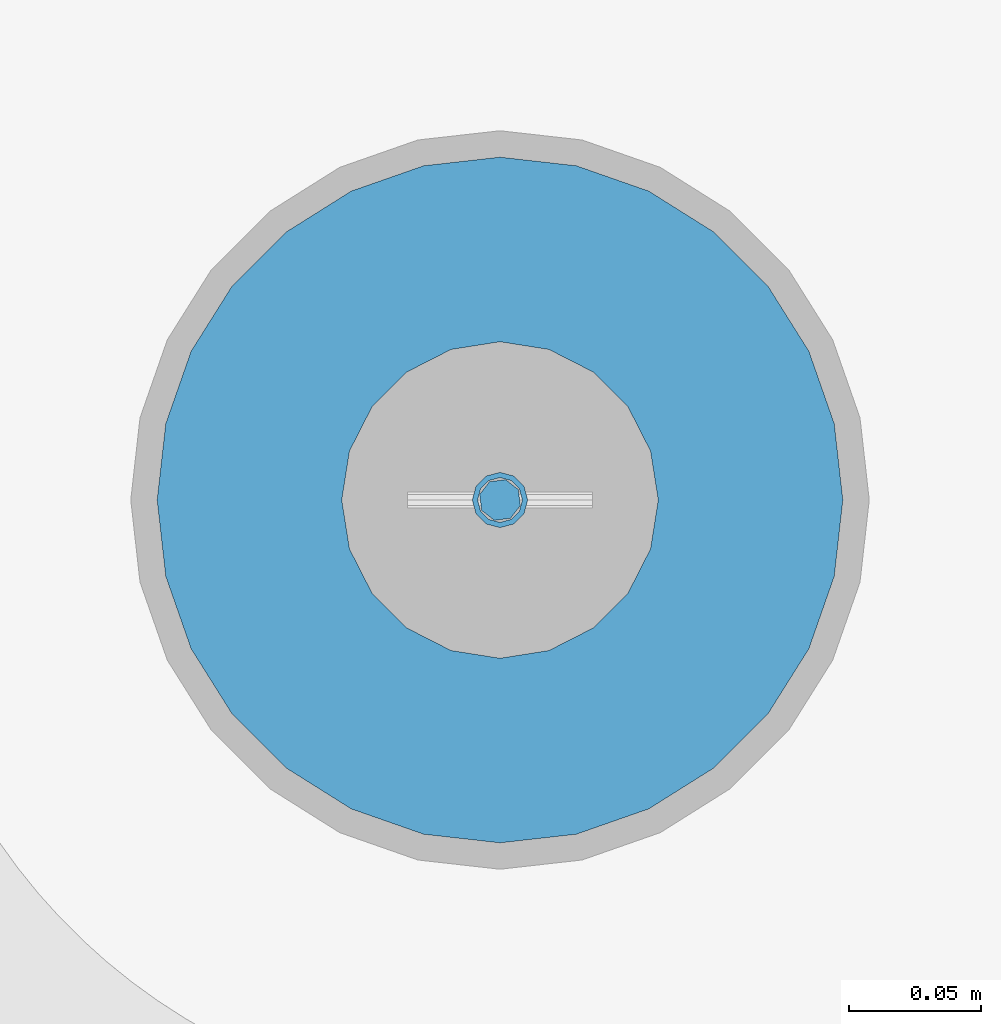
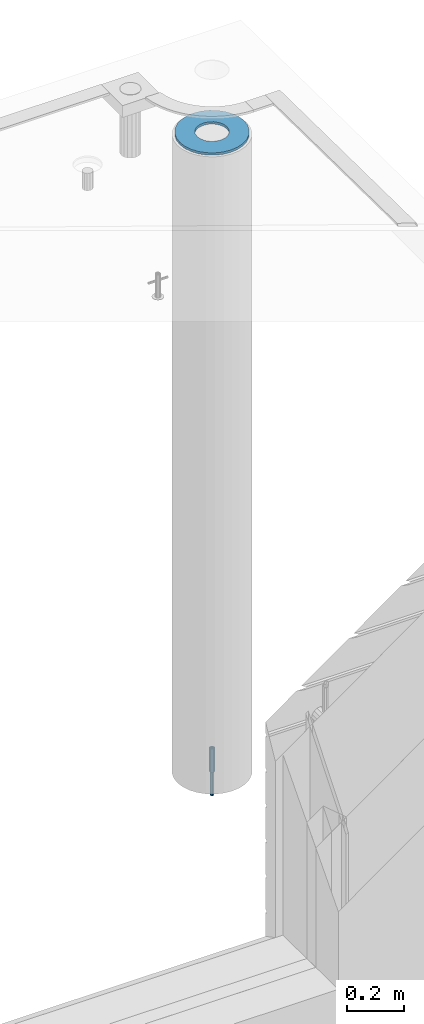
# One storey, part 36 of 334: 3 columns, 3 elements without a shape of their own.
"""IFC2X3 building model written with IfcOpenShell, lengths in millimetres."""

from ifc_helpers import new_model, si_unit, frame, origin_with_axes, place, context, subcontext, project, spatial, faceted_brep, material, type_object, element, aggregate, save


model = new_model("IFC2X3")

# Units and contexts
model_context = context("Model", 3, precision=1e-05, world=origin_with_axes())
body_context = subcontext(model_context, "Body", "Model", "MODEL_VIEW")
ifc_project = project(units=[si_unit("LENGTHUNIT", "METRE", prefix="MILLI"), si_unit("AREAUNIT", "SQUARE_METRE"), si_unit("VOLUMEUNIT", "CUBIC_METRE"), si_unit("MASSUNIT", "GRAM", prefix="KILO"), si_unit("TIMEUNIT", "SECOND"), si_unit("PLANEANGLEUNIT", "RADIAN"), si_unit("SOLIDANGLEUNIT", "STERADIAN"), si_unit("THERMODYNAMICTEMPERATUREUNIT", "DEGREE_CELSIUS"), si_unit("LUMINOUSINTENSITYUNIT", "LUMEN")], contexts=[model_context])

# Site, building, storey
site_placement = place(None, origin_with_axes())
site = spatial("IfcSite", under=ifc_project, at=site_placement, CompositionType="ELEMENT")
building_placement = place(site_placement, origin_with_axes())
building = spatial("IfcBuilding", under=site, at=building_placement, CompositionType="ELEMENT")
storey_placement = place(building_placement, origin_with_axes())
storey = spatial("IfcBuildingStorey", under=building, at=storey_placement, Name="3", CompositionType="ELEMENT", Elevation=0.0)

# Assemblies, columns
assembly_1_placement = place(storey_placement, origin_with_axes())
assembly_1 = element("IfcElementAssembly", 1, at=assembly_1_placement, inside=storey, AssemblyPlace="NOTDEFINED", PredefinedType="REINFORCEMENT_UNIT")
assembly_2_placement = place(assembly_1_placement, origin_with_axes())
assembly_2 = element("IfcElementAssembly", 2, at=assembly_2_placement, Name="Steel Assembly", AssemblyPlace="NOTDEFINED", PredefinedType="RIGID_FRAME")
ifc_material_1 = material(Name="STEEL/S235JR")
column_type_1 = type_object("IfcColumnType", Name="D16", PredefinedType="NOTDEFINED")
column_1_placement = place(assembly_2_placement, frame((35010.0004801435, 22669.9842012047, 87625.0), z_axis=(-0.261346946111888, -0.96524492941325, 0.0), x_axis=(0.0, 0.0, 1.0)))
column_1 = element("IfcColumn", 3, at=column_1_placement, type_object=column_type_1, material=ifc_material_1, Name="M16", ObjectType="D16", context=body_context, shape_type="Brep", body=[
    faceted_brep([(0.0, -8.0, 0.0), (0.0, -5.65685424949334, -5.65685424949334), (150.0, -5.65685424949697, -5.65685424949334), (150.0, -8.00000000000364, 0.0), (0.0, 0.0, -8.0), (150.0, -7.27595761418343e-12, -7.99999999999636), (0.0, 5.65685424949334, -5.65685424949334), (150.0, 5.6568542494897, -5.65685424949334), (0.0, 8.0, 0.0), (150.0, 8.0, -3.63797880709171e-12), (0.0, 5.65685424949334, 5.65685424949334), (150.0, 5.65685424949334, 5.65685424949697), (0.0, 0.0, 8.0), (150.0, -3.63797880709171e-12, 8.0), (0.0, -5.65685424949334, 5.65685424949334), (150.0, -5.65685424949334, 5.6568542494897)], [[[0, 1, 2, 3]], [[1, 4, 5, 2]], [[4, 6, 7, 5]], [[6, 8, 9, 7]], [[8, 10, 11, 9]], [[10, 12, 13, 11]], [[12, 14, 15, 13]], [[14, 0, 3, 15]], [[5, 7, 9, 11, 13, 15, 3, 2]], [[14, 12, 10, 8, 6, 4, 1, 0]]]),
])
aggregate(assembly_2, [column_1])
assembly_3_placement = place(assembly_1_placement, origin_with_axes())
assembly_3 = element("IfcElementAssembly", 4, at=assembly_3_placement, Name="Steel Assembly", AssemblyPlace="NOTDEFINED", PredefinedType="RIGID_FRAME")
ifc_material_2 = material(Name="STEEL/Steel_Undefined")
column_type_2 = type_object("IfcColumnType", PredefinedType="NOTDEFINED")
column_2_placement = place(assembly_3_placement, frame((35009.9987952044, 22669.984888838, 87725.0), z_axis=(0.0, 1.0, 0.0), x_axis=(0.0, 0.0, 1.0)))
column_2 = element("IfcColumn", 5, at=column_2_placement, type_object=column_type_2, material=ifc_material_2, context=body_context, shape_type="Brep", body=[
    faceted_brep([(0.0, -8.49999999999272, -1.45519152283669e-11), (0.0, -7.36121593215648, 4.24999999998545), (100.000000000262, -7.36121593215648, 4.24999999998545), (100.000000000262, -8.49999999999272, -1.45519152283669e-11), (0.0, -4.24999999998545, 7.36121593216376), (100.000000000262, -4.24999999998545, 7.36121593216376), (0.0, 1.45519152283669e-11, 8.49999999998545), (100.000000000262, 1.45519152283669e-11, 8.49999999998545), (0.0, 4.25000000001455, 7.36121593216376), (100.000000000262, 4.25000000001455, 7.36121593216376), (0.0, 7.36121593217104, 4.24999999998545), (100.000000000262, 7.36121593217104, 4.24999999998545), (0.0, 8.50000000000728, 0.0), (100.000000000262, 8.50000000000728, 0.0), (0.0, 7.36121593217104, -4.25000000001455), (100.000000000262, 7.36121593217104, -4.25000000001455), (0.0, 4.25000000000728, -7.36121593219286), (100.000000000262, 4.25000000000728, -7.36121593219286), (0.0, 7.27595761418343e-12, -8.5), (100.000000000262, 7.27595761418343e-12, -8.5), (0.0, -4.24999999999272, -7.36121593217831), (100.000000000262, -4.24999999999272, -7.36121593217831), (0.0, -7.36121593215648, -4.25), (100.000000000262, -7.36121593215648, -4.25), (0.0, -10.4999999999927, -1.45519152283669e-11), (0.0, -9.09326673972828, -5.25000000001455), (100.000000000262, -9.09326673972828, -5.25000000001455), (100.000000000262, -10.4999999999927, -1.45519152283669e-11), (0.0, -5.24999999998545, -9.09326673974283), (100.000000000262, -5.24999999998545, -9.09326673974283), (0.0, 7.27595761418343e-12, -10.5), (100.000000000262, 7.27595761418343e-12, -10.5), (0.0, 5.25000000001455, -9.09326673975738), (100.000000000262, 5.25000000001455, -9.09326673975738), (0.0, 9.09326673975011, -5.25000000001455), (100.000000000262, 9.09326673975011, -5.25000000001455), (0.0, 10.5000000000073, -1.45519152283669e-11), (100.000000000262, 10.5000000000073, -1.45519152283669e-11), (0.0, 9.09326673975011, 5.25), (100.000000000262, 9.09326673975011, 5.25), (0.0, 5.25000000000728, 9.09326673972828), (100.000000000262, 5.25000000000728, 9.09326673972828), (0.0, 1.45519152283669e-11, 10.4999999999854), (100.000000000262, 1.45519152283669e-11, 10.4999999999854), (0.0, -5.24999999999272, 9.09326673972828), (100.000000000262, -5.24999999999272, 9.09326673972828), (0.0, -9.09326673972828, 5.24999999998545), (100.000000000262, -9.09326673972828, 5.24999999998545)], [[[0, 1, 2, 3]], [[1, 4, 5, 2]], [[4, 6, 7, 5]], [[6, 8, 9, 7]], [[8, 10, 11, 9]], [[10, 12, 13, 11]], [[12, 14, 15, 13]], [[14, 16, 17, 15]], [[16, 18, 19, 17]], [[18, 20, 21, 19]], [[20, 22, 23, 21]], [[22, 0, 3, 23]], [[24, 25, 26, 27]], [[25, 28, 29, 26]], [[28, 30, 31, 29]], [[30, 32, 33, 31]], [[32, 34, 35, 33]], [[34, 36, 37, 35]], [[36, 38, 39, 37]], [[38, 40, 41, 39]], [[40, 42, 43, 41]], [[42, 44, 45, 43]], [[44, 46, 47, 45]], [[46, 24, 27, 47]], [[29, 31, 33, 35, 37, 39, 41, 43, 45, 47, 27, 26], [5, 7, 9, 11, 13, 15, 17, 19, 21, 23, 3, 2]], [[46, 44, 42, 40, 38, 36, 34, 32, 30, 28, 25, 24], [22, 20, 18, 16, 14, 12, 10, 8, 6, 4, 1, 0]]]),
])
aggregate(assembly_3, [column_2])
ifc_material_3 = material()
column_type_3 = type_object("IfcColumnType", Name="D260", PredefinedType="NOTDEFINED")
column_3_placement = place(assembly_1_placement, frame((35009.9987952044, 22669.984888838, 90435.0), z_axis=(-1.0, 3.00000001838171e-08, 0.0), x_axis=(0.0, 0.0, 1.0)))
column_3 = element("IfcColumn", 6, at=column_3_placement, type_object=column_type_3, material=ifc_material_3, Name="60", ObjectType="D260", context=body_context, shape_type="Brep", body=[
    faceted_brep([(10.0, -18.541019662498, -57.0633909777098), (0.0, -18.541019662498, -57.0633909777098), (0.0, -35.2671151375471, -48.5410196624944), (10.0, -35.2671151375471, -48.5410196624944), (0.0, -48.541019662498, -35.2671151375471), (10.0, -48.541019662498, -35.2671151375471), (0.0, -57.0633909777098, -18.5410196624944), (10.0, -57.0633909777098, -18.5410196624944), (0.0, -60.0, 0.0), (10.0, -60.0, 0.0), (0.0, -57.0633909777098, 18.5410196624944), (10.0, -57.0633909777098, 18.5410196624944), (0.0, -48.541019662498, 35.2671151375471), (10.0, -48.541019662498, 35.2671151375471), (0.0, -35.2671151375471, 48.5410196624944), (10.0, -35.2671151375471, 48.5410196624944), (0.0, -18.541019662498, 57.0633909777098), (10.0, -18.541019662498, 57.0633909777098), (0.0, 0.0, 60.0), (10.0, 0.0, 60.0), (0.0, 18.541019662498, 57.0633909777098), (10.0, 18.541019662498, 57.0633909777098), (0.0, 35.2671151375471, 48.5410196624944), (10.0, 35.2671151375471, 48.5410196624944), (0.0, 48.541019662498, 35.2671151375471), (10.0, 48.541019662498, 35.2671151375471), (0.0, 57.0633909777098, 18.5410196624944), (10.0, 57.0633909777098, 18.5410196624944), (0.0, 60.0, 0.0), (10.0, 60.0, 0.0), (0.0, 57.0633909777098, -18.5410196624944), (10.0, 57.0633909777098, -18.5410196624944), (0.0, 48.541019662498, -35.2671151375471), (10.0, 48.541019662498, -35.2671151375471), (0.0, 35.2671151375471, -48.5410196624944), (10.0, 35.2671151375471, -48.5410196624944), (0.0, 18.541019662498, -57.0633909777098), (10.0, 18.541019662498, -57.0633909777098), (0.0, 0.0, -60.0), (10.0, 0.0, -60.0), (0.0, -126.740628583637, -28.9277214143222), (0.0, -117.125952827315, -56.4048860852854), (10.0, -117.125952827315, -56.4048860852854), (10.0, -126.740628583637, -28.9277214143222), (0.0, -101.638092720845, -81.0536742416371), (10.0, -101.638092720845, -81.0536742416371), (0.0, -81.0536742416371, -101.638092720845), (10.0, -81.0536742416371, -101.638092720845), (0.0, -56.4048860852818, -117.125952827315), (10.0, -56.4048860852818, -117.125952827315), (0.0, -28.9277214143222, -126.740628583641), (10.0, -28.9277214143222, -126.740628583641), (0.0, 0.0, -130.0), (10.0, 0.0, -130.0), (0.0, 28.9277214143222, -126.740628583641), (10.0, 28.9277214143222, -126.740628583641), (0.0, 56.4048860852818, -117.125952827315), (10.0, 56.4048860852818, -117.125952827315), (0.0, 81.0536742416371, -101.638092720845), (10.0, 81.0536742416371, -101.638092720845), (0.0, 101.638092720845, -81.0536742416371), (10.0, 101.638092720845, -81.0536742416371), (0.0, 117.125952827315, -56.4048860852854), (10.0, 117.125952827315, -56.4048860852854), (0.0, 126.740628583637, -28.9277214143222), (10.0, 126.740628583637, -28.9277214143222), (0.0, 130.0, -1.81898940354586e-12), (10.0, 130.0, 0.0), (0.0, 126.740628583637, 28.9277214143222), (10.0, 126.740628583637, 28.9277214143222), (0.0, 117.125952827315, 56.4048860852854), (10.0, 117.125952827315, 56.4048860852854), (0.0, 101.638092720845, 81.0536742416371), (10.0, 101.638092720845, 81.0536742416371), (0.0, 81.0536742416371, 101.638092720845), (10.0, 81.0536742416371, 101.638092720845), (0.0, 56.4048860852818, 117.125952827315), (10.0, 56.4048860852818, 117.125952827315), (0.0, 28.9277214143222, 126.740628583641), (10.0, 28.9277214143222, 126.740628583641), (0.0, 0.0, 130.0), (10.0, 0.0, 130.0), (0.0, -28.9277214143222, 126.740628583641), (10.0, -28.9277214143222, 126.740628583641), (0.0, -56.4048860852818, 117.125952827315), (10.0, -56.4048860852818, 117.125952827315), (0.0, -81.0536742416371, 101.638092720845), (10.0, -81.0536742416371, 101.638092720845), (0.0, -101.638092720845, 81.0536742416371), (10.0, -101.638092720845, 81.0536742416371), (0.0, -117.125952827315, 56.4048860852854), (10.0, -117.125952827315, 56.4048860852854), (0.0, -126.740628583637, 28.9277214143222), (10.0, -126.740628583637, 28.9277214143222), (0.0, -130.0, -3.63797880709171e-12), (10.0, -130.0, 0.0)], [[[0, 1, 2, 3]], [[3, 2, 4, 5]], [[5, 4, 6, 7]], [[7, 6, 8, 9]], [[9, 8, 10, 11]], [[11, 10, 12, 13]], [[13, 12, 14, 15]], [[15, 14, 16, 17]], [[17, 16, 18, 19]], [[19, 18, 20, 21]], [[21, 20, 22, 23]], [[23, 22, 24, 25]], [[25, 24, 26, 27]], [[27, 26, 28, 29]], [[29, 28, 30, 31]], [[31, 30, 32, 33]], [[33, 32, 34, 35]], [[35, 34, 36, 37]], [[37, 36, 38, 39]], [[39, 38, 1, 0]], [[40, 41, 42, 43]], [[41, 44, 45, 42]], [[44, 46, 47, 45]], [[46, 48, 49, 47]], [[48, 50, 51, 49]], [[50, 52, 53, 51]], [[52, 54, 55, 53]], [[54, 56, 57, 55]], [[56, 58, 59, 57]], [[58, 60, 61, 59]], [[60, 62, 63, 61]], [[62, 64, 65, 63]], [[64, 66, 67, 65]], [[66, 68, 69, 67]], [[68, 70, 71, 69]], [[70, 72, 73, 71]], [[72, 74, 75, 73]], [[74, 76, 77, 75]], [[76, 78, 79, 77]], [[78, 80, 81, 79]], [[80, 82, 83, 81]], [[82, 84, 85, 83]], [[84, 86, 87, 85]], [[86, 88, 89, 87]], [[88, 90, 91, 89]], [[90, 92, 93, 91]], [[92, 94, 95, 93]], [[42, 45, 47, 49, 51, 53, 55, 57, 59, 61, 63, 65, 67, 69, 71, 73, 75, 77, 79, 81, 83, 85, 87, 89, 91, 93, 95, 43], [3, 5, 7, 9, 11, 13, 15, 17, 19, 21, 23, 25, 27, 29, 31, 33, 35, 37, 39, 0]], [[94, 40, 43, 95]], [[92, 90, 88, 86, 84, 82, 80, 78, 76, 74, 72, 70, 68, 66, 64, 62, 60, 58, 56, 54, 52, 50, 48, 46, 44, 41, 40, 94], [34, 32, 30, 28, 26, 24, 22, 20, 18, 16, 14, 12, 10, 8, 6, 4, 2, 1, 38, 36]]]),
])
aggregate(assembly_1, [assembly_3, assembly_2, column_3])

save(model, "model.ifc")
